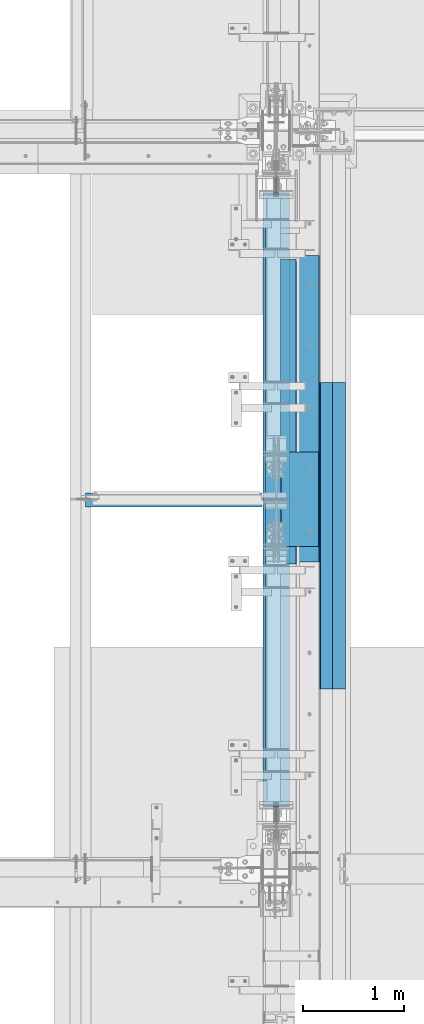
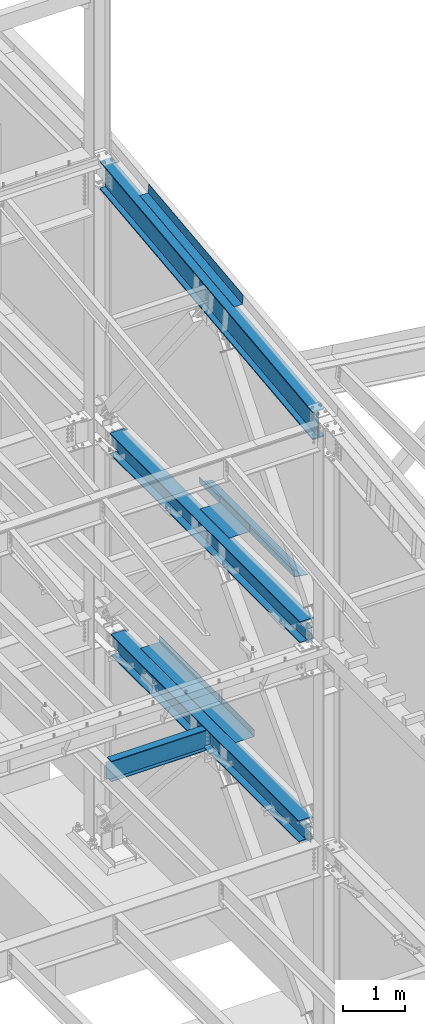
# One storey, part 742 of 1179: 9 beams, 6 elements without a shape of their own.
"""IFC2X3 building model written with IfcOpenShell, lengths in millimetres."""

from ifc_helpers import new_model, si_unit, frame, origin_with_axes, place, context, subcontext, project, spatial, faceted_brep, material, type_object, element, aggregate, save


model = new_model("IFC2X3")

# Units and contexts
model_context = context("Model", 3, precision=1e-05, world=origin_with_axes())
body_context = subcontext(model_context, "Body", "Model", "MODEL_VIEW")
ifc_project = project(units=[si_unit("LENGTHUNIT", "METRE", prefix="MILLI"), si_unit("AREAUNIT", "SQUARE_METRE"), si_unit("VOLUMEUNIT", "CUBIC_METRE"), si_unit("MASSUNIT", "GRAM", prefix="KILO"), si_unit("TIMEUNIT", "SECOND"), si_unit("PLANEANGLEUNIT", "RADIAN"), si_unit("SOLIDANGLEUNIT", "STERADIAN"), si_unit("THERMODYNAMICTEMPERATUREUNIT", "DEGREE_CELSIUS"), si_unit("LUMINOUSINTENSITYUNIT", "LUMEN")], contexts=[model_context])

# Site, building, storey
site_placement = place(None, origin_with_axes())
site = spatial("IfcSite", under=ifc_project, at=site_placement, CompositionType="ELEMENT")
building_placement = place(site_placement, origin_with_axes())
building = spatial("IfcBuilding", under=site, at=building_placement, Name="Undefined", CompositionType="ELEMENT")
storey_placement = place(building_placement, origin_with_axes())
storey = spatial("IfcBuildingStorey", under=building, at=storey_placement, Name="Undefined", CompositionType="ELEMENT", Elevation=0.0)

# Assembly, beam
assembly_1_placement = place(storey_placement, origin_with_axes())
assembly_1 = element("IfcElementAssembly", 1, at=assembly_1_placement, inside=storey, Name="BEAM", AssemblyPlace="NOTDEFINED", PredefinedType="RIGID_FRAME")
ifc_material_1 = material(Name="STEEL/A992")
beam_type_1 = type_object("IfcBeamType", Name="W16X31", PredefinedType="NOTDEFINED")
beam_1_placement = place(assembly_1_placement, frame((22326.6, 30721.3, 3900.4875), z_axis=(0.0, 0.0, 1.0), x_axis=(1.0, 0.0, 0.0)))
beam_1 = element("IfcBeam", 2, at=beam_1_placement, type_object=beam_type_1, material=ifc_material_1, Name="BEAM", ObjectType="W16X31", context=body_context, shape_type="Brep", body=[
    faceted_brep([(15.875, -3.17499999999927, -169.8625), (15.875, 3.17499999999927, -169.8625), (69.8500001907269, 3.17499999999927, -169.8625), (69.8500001907269, -3.17499999999927, -169.8625), (74.7100797087733, 3.17499999999927, -170.829229922588), (74.7100797087733, -3.17499999999927, -170.829229922588), (78.8302561769269, 3.17499999999927, -173.582243823066), (78.8302561769269, -3.17499999999927, -173.582243823066), (81.5832700774044, 3.17499999999927, -177.70242029122), (81.5832700774044, -3.17499999999927, -177.70242029122), (82.549999999992, -3.17499999999927, -182.562499809265), (82.549999999992, 3.17499999999927, -182.562499809265), (82.549999999992, 3.17499999999927, -190.5), (82.549999999992, 69.8499999999985, -190.5), (82.549999999992, 69.8499999999985, -201.6125), (82.549999999992, -69.8499999999985, -201.6125), (82.549999999992, -69.8499999999985, -190.5), (82.549999999992, -3.17499999999927, -190.5), (1839.11875, 69.8499999999985, 190.5), (1839.11875, 3.17499999999927, 190.5), (82.549999999992, 3.17499999999927, 190.5), (82.549999999992, 69.8499999999985, 190.5), (69.8500001907269, -3.17499999999927, 169.8625), (69.8500001907269, 3.17499999999927, 169.8625), (15.875, 3.17499999999927, 169.8625), (15.875, -3.17499999999927, 169.8625), (74.7100797087733, -3.17499999999927, 170.829229922588), (74.7100797087733, 3.17499999999927, 170.829229922588), (78.8302561769269, -3.17499999999927, 173.582243823066), (78.8302561769269, 3.17499999999927, 173.582243823066), (81.5832700774044, -3.17499999999927, 177.70242029122), (81.5832700774044, 3.17499999999927, 177.70242029122), (82.549999999992, -3.17499999999927, 182.562499809265), (82.549999999992, 3.17499999999927, 182.562499809265), (1839.11875, -69.8499999999985, 201.6125), (1839.11875, 69.8499999999985, 201.6125), (82.549999999992, 69.8499999999985, 201.6125), (82.549999999992, -69.8499999999985, 201.6125), (1839.11875, -69.8499999999985, 190.5), (82.549999999992, -69.8499999999985, 190.5), (1839.11875, -3.17499999999927, 190.5), (82.549999999992, -3.17499999999927, 190.5), (1839.11875, -3.17499999999927, 169.862499809265), (1839.11875, 3.17499999999927, 169.862499809265), (1840.08547992259, -3.17499999999927, 165.00242029122), (1840.08547992259, 3.17499999999927, 165.00242029122), (1842.83849382307, -3.17499999999927, 160.882243823066), (1842.83849382307, 3.17499999999927, 160.882243823066), (1846.95867029122, -3.17499999999927, 158.129229922588), (1846.95867029122, 3.17499999999927, 158.129229922588), (1851.81874980927, -3.17499999999927, 157.1625), (1851.81874980927, 3.17499999999927, 157.1625), (1962.94375000001, -3.17499999999927, 157.1625), (1962.94375000001, 3.17499999999927, 157.1625), (1962.94375000001, -3.17499999999927, -157.1625), (1962.94375000001, 3.17499999999927, -157.1625), (1851.81874980927, -3.17499999999927, -157.1625), (1851.81874980927, 3.17499999999927, -157.1625), (1846.95867029122, -3.17499999999927, -158.129229922588), (1846.95867029122, 3.17499999999927, -158.129229922588), (1842.83849382307, -3.17499999999927, -160.882243823066), (1842.83849382307, 3.17499999999927, -160.882243823066), (1840.08547992259, -3.17499999999927, -165.00242029122), (1840.08547992259, 3.17499999999927, -165.00242029122), (1839.11875, -3.17499999999927, -169.862499809266), (1839.11875, 3.17499999999927, -169.862499809266), (1839.11875, -3.17499999999927, -190.5), (1839.11875, -69.8499999999985, -190.5), (1839.11875, -69.8499999999985, -201.6125), (1839.11875, 69.8499999999985, -201.6125), (1839.11875, 69.8499999999985, -190.5), (1839.11875, 3.17499999999927, -190.5)], [[[0, 1, 2, 3]], [[3, 2, 4, 5]], [[5, 4, 6, 7]], [[7, 6, 8, 9]], [[10, 11, 12, 13, 14, 15, 16, 17]], [[9, 8, 11, 10]], [[18, 19, 20, 21]], [[22, 23, 24, 25]], [[26, 27, 23, 22]], [[28, 29, 27, 26]], [[30, 31, 29, 28]], [[32, 33, 31, 30]], [[34, 35, 36, 37]], [[38, 34, 37, 39]], [[40, 38, 39, 41]], [[37, 36, 21, 20, 33, 32, 41, 39]], [[35, 18, 21, 36]], [[34, 38, 40, 42, 43, 19, 18, 35]], [[44, 45, 43, 42]], [[46, 47, 45, 44]], [[48, 49, 47, 46]], [[50, 51, 49, 48]], [[52, 53, 51, 50]], [[53, 52, 54, 55]], [[54, 56, 57, 55]], [[58, 59, 57, 56]], [[60, 61, 59, 58]], [[62, 63, 61, 60]], [[64, 65, 63, 62]], [[66, 67, 68, 69, 70, 71, 65, 64]], [[67, 66, 17, 16]], [[68, 67, 16, 15]], [[69, 68, 15, 14]], [[70, 69, 14, 13]], [[71, 70, 13, 12]], [[6, 4, 2, 1, 24, 23, 27, 29, 31, 33, 20, 19, 43, 45, 47, 49, 51, 53, 55, 57, 59, 61, 63, 65, 71, 12, 11, 8]], [[25, 24, 1, 0]], [[66, 64, 62, 60, 58, 56, 54, 52, 50, 48, 46, 44, 42, 40, 41, 32, 30, 28, 26, 22, 25, 0, 3, 5, 7, 9, 10, 17]]]),
])
aggregate(assembly_1, [beam_1])

assembly_2_placement = place(storey_placement, origin_with_axes())
assembly_2 = element("IfcElementAssembly", 3, at=assembly_2_placement, inside=storey, Name="BEAM", AssemblyPlace="NOTDEFINED", PredefinedType="RIGID_FRAME")
ifc_material_2 = material(Name="STEEL/A36")
beam_type_2 = type_object("IfcBeamType", PredefinedType="NOTDEFINED")
beam_2_placement = place(assembly_2_placement, frame((24350.663, 31596.8008477536, 12820.4719325698), z_axis=(0.0, -0.993676146336441, -0.112284087038017), x_axis=(1.0, 0.0, 0.0)))
beam_2 = element("IfcBeam", 4, at=beam_2_placement, type_object=beam_type_2, material=ifc_material_2, Name="BENT_PLATE", context=body_context, shape_type="Brep", body=[
    faceted_brep([(0.0, -3.17499999999927, -1524.0), (6.00266503170133e-10, -3.17499999922438, 1524.00000000052), (6.00266503170133e-10, 3.17500000077416, 1524.00000000052), (0.0, 3.17499999999927, -1524.0), (153.987000024775, 3.17499999922438, 1524.00000000046), (153.987000022519, 3.17500000077052, -1524.00000000059), (160.337000000047, -3.17500000061591, -1523.99999999915), (160.336999999981, -3.17499999938082, 1523.99999999915), (153.987000000016, 187.325000000103, 1523.99999999907), (153.987000000016, 187.324999998867, -1523.99999999923), (160.337000000014, 187.325000000103, 1523.99999999907), (160.337000000014, 187.324999998867, -1523.99999999923)], [[[0, 1, 2, 3]], [[3, 2, 4, 5]], [[1, 0, 6, 7]], [[5, 4, 8, 9]], [[4, 2, 1, 7, 10, 8]], [[7, 6, 11, 10]], [[6, 0, 3, 5, 9, 11]], [[10, 11, 9, 8]]]),
])

assembly_3_placement = place(storey_placement, origin_with_axes())
assembly_3 = element("IfcElementAssembly", 5, at=assembly_3_placement, inside=storey, Name="PLATE", AssemblyPlace="NOTDEFINED", PredefinedType="RIGID_FRAME")
beam_type_3 = type_object("IfcBeamType", PredefinedType="NOTDEFINED")
beam_3_placement = place(assembly_3_placement, frame((24880.9652345644, 28841.6999999996, 7964.0487255808), z_axis=(-0.99100656978554, 0.0, 0.133813222971043), x_axis=(0.0, 1.0, 0.0)))
beam_3 = element("IfcBeam", 6, at=beam_3_placement, type_object=beam_type_3, material=ifc_material_2, Name="PLATE", context=body_context, shape_type="Brep", body=[
    faceted_brep([(0.0, 4.76249999999709, -114.3), (0.0, 4.76249999999709, 114.3), (3048.0, 4.76249999996799, 114.300000000025), (3048.0, 4.76250000002983, -114.300000000025), (0.0, -4.76249999999709, 114.3), (3048.0, -4.76250000003711, 114.300000000014), (0.0, -4.76249999999709, -114.3), (3048.0, -4.76249999997344, -114.300000000036)], [[[0, 1, 2, 3]], [[1, 4, 5, 2]], [[4, 6, 7, 5]], [[6, 0, 3, 7]], [[5, 7, 3, 2]], [[6, 4, 1, 0]]]),
])
aggregate(assembly_3, [beam_3])

assembly_4_placement = place(storey_placement, origin_with_axes())
assembly_4 = element("IfcElementAssembly", 7, at=assembly_4_placement, inside=storey, Name="BEAM", AssemblyPlace="NOTDEFINED", PredefinedType="RIGID_FRAME")
beam_type_4 = type_object("IfcBeamType", PredefinedType="NOTDEFINED")
beam_4_placement = place(assembly_4_placement, frame((24387.175012207, 31626.175, 4105.275), z_axis=(0.0, -1.0, 0.0), x_axis=(1.0, 0.0, 0.0)))
beam_4 = element("IfcBeam", 8, at=beam_4_placement, type_object=beam_type_4, material=ifc_material_2, Name="BENT_PLATE", context=body_context, shape_type="Brep", body=[
    faceted_brep([(0.0, -3.17499999999927, -1524.0), (6.00266503170133e-10, -3.17499999922438, 1524.00000000052), (6.00266503170133e-10, 3.17500000077416, 1524.00000000052), (0.0, 3.17499999999927, -1524.0), (346.07498779297, 3.17500000000109, 1524.0), (346.07498779297, 3.17500000000109, -1524.0), (352.424987792969, -3.17499999999927, -1524.0), (352.424987792969, -3.17499999999927, 1524.0), (346.07498779297, 130.175006103515, 1524.0), (346.07498779297, 130.175006103515, -1524.0), (352.424987792969, 130.175006103515, 1524.0), (352.424987792969, 130.175006103515, -1524.0)], [[[0, 1, 2, 3]], [[3, 2, 4, 5]], [[1, 0, 6, 7]], [[5, 4, 8, 9]], [[4, 2, 1, 7, 10, 8]], [[7, 6, 11, 10]], [[6, 0, 3, 5, 9, 11]], [[10, 11, 9, 8]]]),
])

assembly_5_placement = place(storey_placement, origin_with_axes())
assembly_5 = element("IfcElementAssembly", 9, at=assembly_5_placement, inside=storey, Name="BEAM", AssemblyPlace="NOTDEFINED", PredefinedType="RIGID_FRAME")
beam_type_5 = type_object("IfcBeamType", PredefinedType="NOTDEFINED")
beam_5_placement = place(assembly_5_placement, frame((24361.7750019084, 30727.6499996401, 8018.4625), z_axis=(0.0, 1.0, 0.0), x_axis=(1.0, 0.0, 0.0)))
beam_5 = element("IfcBeam", 10, at=beam_5_placement, type_object=beam_type_5, material=ifc_material_2, Name="BENT_PLATE", context=body_context, shape_type="Brep", body=[
    faceted_brep([(1.15323928184807e-09, -4.76249999999982, -469.900000000001), (3.16504156216979e-10, -4.76249999999982, 469.900000000001), (-1.14960130304098e-09, 4.76249999999982, 469.900000000001), (-3.12866177409887e-10, 4.76249999999982, -469.900000000001), (377.825003325797, 4.76250005815837, 469.900000000336), (377.825003326634, 4.76250005815837, -469.899999999663), (368.300003174245, -4.76249994330828, -469.89999999967), (368.300003173408, -4.76249994330828, 469.900000000333), (377.825001192323, -128.587512194506, 469.900000000336), (377.82500119316, -128.587512194506, -469.899999999663), (368.300001192321, -128.587512042115, 469.900000000333), (368.300001193158, -128.587512042115, -469.89999999967)], [[[0, 1, 2, 3]], [[3, 2, 4, 5]], [[1, 0, 6, 7]], [[5, 4, 8, 9]], [[4, 2, 1, 7, 10, 8]], [[7, 6, 11, 10]], [[6, 0, 3, 5, 9, 11]], [[10, 11, 9, 8]]]),
])

assembly_6_placement = place(storey_placement, origin_with_axes())
assembly_6 = element("IfcElementAssembly", 11, at=assembly_6_placement, inside=storey, Name="BENT_PLATE", AssemblyPlace="NOTDEFINED", PredefinedType="RIGID_FRAME")
beam_type_6 = type_object("IfcBeamType", PredefinedType="NOTDEFINED")
beam_6_placement = place(assembly_6_placement, frame((24744.362499997, 30365.6999999996, 8102.29217706219), z_axis=(0.0, 1.0, 0.0), x_axis=(0.0, 0.0, -1.0)))
beam_6 = element("IfcBeam", 12, at=beam_6_placement, type_object=beam_type_6, material=ifc_material_2, Name="BENT_PLATE", context=body_context, shape_type="Brep", body=[
    faceted_brep([(-2.91038304567337e-11, -4.76250000000073, -1524.0), (-2.91038304567337e-11, -4.76250000000073, 1524.0), (2.91038304567337e-11, 4.76250000000073, 1524.0), (2.91038304567337e-11, 4.76250000000073, -1524.0), (114.300008765535, 4.76250001759399, 1524.0000000001), (114.300003051474, 4.7625000005828, -1524.0), (105.977955544956, -4.76249999945867, -1524.0), (105.977955544956, -4.76249999945867, 1524.0), (131.343048095475, -121.088742065571, 1524.0), (131.343048095475, -121.088742065571, -1524.0), (121.904205090902, -122.366970423507, 1524.0), (121.904205090902, -122.366970423507, -1524.0)], [[[0, 1, 2, 3]], [[3, 2, 4, 5]], [[1, 0, 6, 7]], [[5, 4, 8, 9]], [[4, 2, 1, 7, 10, 8]], [[7, 6, 11, 10]], [[6, 0, 3, 5, 9, 11]], [[10, 11, 9, 8]]]),
])
aggregate(assembly_6, [beam_6])

# Beam
beam_type_7 = type_object("IfcBeamType", Name="W21X93", PredefinedType="NOTDEFINED")
beam_7_placement = place(assembly_2_placement, frame((24307.8, 27081.8467562485, 12030.7075801958), z_axis=(0.0, -0.112284087038017, 0.993676146336441), x_axis=(0.0, 0.993676146336441, 0.112284087038017)))
beam_7 = element("IfcBeam", 13, at=beam_7_placement, type_object=beam_type_7, material=ifc_material_1, Name="BEAM", ObjectType="W21X93", context=body_context, shape_type="Brep", body=[
    faceted_brep([(199.930151815766, -106.362499999999, -274.637499999924), (199.930151815766, 106.362499999999, -274.637499999924), (7061.63506944101, 106.362499999999, -274.637500002709), (7061.63506944101, -106.362499999999, -274.637500002709), (202.620932743182, -106.362499999999, -250.824999999939), (202.620932743182, -7.14374999999927, -250.824999999939), (259.306717614098, -7.14374999999927, 250.824999999757), (259.306717614098, -106.362499999999, 250.824999999757), (261.997498541514, -106.362499999999, 274.637499999742), (261.997498541514, 106.362499999999, 274.637499999742), (259.306717614098, 106.362499999999, 250.824999999757), (259.306717614098, 7.14374999999927, 250.824999999757), (259.165541301165, 7.14374999999927, 249.575637438333), (214.511782852362, 7.14374999999927, -145.595003258246), (202.620932743182, 7.14374999999927, -250.824999999939), (202.620932743182, 106.362499999999, -250.824999999939), (7064.32585036842, -106.362499999999, -250.825000002722), (7064.32585036842, -7.14374999999927, -250.825000002722), (7121.01163523934, -7.14374999999927, 250.824999996972), (7121.01163523934, -106.362499999999, 250.824999996972), (7123.70241616675, -106.362499999999, 274.637499996959), (7123.70241616675, 106.362499999999, 274.637499996959), (7121.01163523934, 106.362499999999, 250.824999996972), (7121.01163523934, 7.14374999999927, 250.824999996972), (7114.9805671698, 7.14374999999927, 197.452089946073), (7070.32680872106, 7.14374999999927, -197.718550750044), (7064.32585036842, 7.14374999999927, -250.825000002722), (7064.32585036842, 106.362499999999, -250.825000002722)], [[[0, 1, 2, 3]], [[0, 4, 5, 6, 7, 8, 9, 10, 11, 12, 13, 14, 15, 1]], [[5, 4, 16, 17]], [[6, 5, 17, 18]], [[7, 6, 18, 19]], [[8, 7, 19, 20]], [[9, 8, 20, 21]], [[10, 9, 21, 22]], [[11, 10, 22, 23]], [[14, 13, 12, 11, 23, 24, 25, 26]], [[15, 14, 26, 27]], [[1, 15, 27, 2]], [[26, 25, 24, 23, 22, 21, 20, 19, 18, 17, 16, 3, 2, 27]], [[4, 0, 3, 16]]]),
])

aggregate(assembly_2, [beam_2, beam_7])

beam_type_8 = type_object("IfcBeamType", Name="W16X77", PredefinedType="NOTDEFINED")
beam_8_placement = place(assembly_5_placement, frame((24307.8, 27504.4088209118, 7804.15), z_axis=(0.0, 0.0, 1.0), x_axis=(0.0, 1.0, 0.0)))
beam_8 = element("IfcBeam", 14, at=beam_8_placement, type_object=beam_type_8, material=ifc_material_1, Name="BEAM", ObjectType="W16X77", context=body_context, shape_type="Brep", body=[
    faceted_brep([(172.923581529496, -130.174999999999, 209.55), (172.923581529496, 130.174999999999, 209.55), (161.925002356769, 130.174999999999, 190.5), (161.925002356769, 5.55625000000146, 190.5), (161.695793121518, 5.55625000000146, 190.103), (161.695793121518, -5.55625000000146, 190.103), (161.925002356769, -5.55625000000146, 190.5), (161.925002356769, -130.174999999999, 190.5), (204.788, -5.55625000000146, 190.103), (204.788, 5.55625000000146, 190.103), (219.364364197005, 5.55625000000146, 183.243356973128), (219.364364197005, -5.55625000000146, 183.243356973128), (223.220112806051, 5.55625000000146, 179.929052423035), (223.220112806051, -5.55625000000146, 179.929052423035), (224.821539280802, 5.55625000000146, 175.103407882364), (224.821539280802, -5.55625000000146, 175.103407882364), (223.71233220007, 5.55625000000146, 170.141445403769), (223.71233220007, -5.55625000000146, 170.141445403769), (220.208549695388, 5.55625000000146, 166.457029554976), (220.208549695388, -5.55625000000146, 166.457029554976), (215.308561657253, 5.55625000000146, 165.1), (215.308561657253, -5.55625000000146, 165.1), (12.7000000000007, 5.55625000000146, 165.1), (12.7000000000007, -5.55625000000146, 165.1), (12.7000000000007, 5.55625000000146, -165.1), (12.7000000000007, -5.55625000000146, -165.1), (215.652561657254, 5.55625000000146, -165.1), (215.652561657254, -5.55625000000146, -165.1), (220.552549695389, 5.55625000000146, -166.457029554975), (220.552549695389, -5.55625000000146, -166.457029554975), (224.056332200067, 5.55625000000146, -170.141445403768), (224.056332200067, -5.55625000000146, -170.141445403768), (225.165539280799, 5.55625000000146, -175.103407882363), (225.165539280799, -5.55625000000146, -175.103407882363), (223.564112806052, 5.55625000000146, -179.929052423034), (223.564112806052, -5.55625000000146, -179.929052423034), (219.708364197006, 5.55625000000146, -183.243356973128), (219.708364197006, -5.55625000000146, -183.243356973128), (205.132000000001, 5.55625000000146, -190.103), (205.132000000001, -5.55625000000146, -190.103), (173.152798769261, 5.55625000000146, -190.103), (173.152798769261, -5.55625000000146, -190.103), (6260.85876063778, 5.55625000000146, -190.5), (6260.85876063778, 130.174999999999, -190.5), (172.923597538524, 130.174999999999, -190.5), (172.923597538524, 5.55625000000146, -190.5), (6271.85695571483, 130.174999999999, -209.55), (161.925402461478, 130.174999999999, -209.55), (6271.85695571483, -130.174999999999, -209.55), (161.925402461478, -130.174999999999, -209.55), (6260.85876063778, -130.174999999999, -190.5), (172.923597538524, -130.174999999999, -190.5), (172.923597538524, -5.55625000000146, -190.5), (6260.85876063778, -5.55625000000146, -190.5), (6260.62955940704, 5.55625000000146, -190.103), (6260.62955940704, -5.55625000000146, -190.103), (6228.6503581763, 5.55625000000146, -190.103), (6228.6503581763, -5.55625000000146, -190.103), (6214.0739939793, 5.55625000000146, -183.243356973128), (6214.0739939793, -5.55625000000146, -183.243356973128), (6210.21824537025, 5.55625000000146, -179.929052423035), (6210.21824537025, -5.55625000000146, -179.929052423035), (6208.61681889551, 5.55625000000146, -175.103407882363), (6208.61681889551, -5.55625000000146, -175.103407882363), (6209.72602597623, 5.55625000000146, -170.141445403768), (6209.72602597623, -5.55625000000146, -170.141445403768), (6213.22980848092, 5.55625000000146, -166.457029554975), (6213.22980848092, -5.55625000000146, -166.457029554975), (6218.12979651905, 5.55625000000146, -165.1), (6218.12979651905, -5.55625000000146, -165.1), (6421.0823581763, 5.55625000000146, -165.1), (6421.0823581763, -5.55625000000146, -165.1), (6421.0823581763, -5.55625000000146, 165.1), (6421.0823581763, 5.55625000000146, 165.1), (6218.47379651905, 5.55625000000146, 165.1), (6218.47379651905, -5.55625000000146, 165.1), (6213.57380848091, 5.55625000000146, 166.457029554975), (6213.57380848091, -5.55625000000146, 166.457029554975), (6210.07002597624, 5.55625000000146, 170.141445403767), (6210.07002597624, -5.55625000000146, 170.141445403767), (6208.9608188955, 5.55625000000146, 175.103407882362), (6208.9608188955, -5.55625000000146, 175.103407882362), (6210.56224537025, 5.55625000000146, 179.929052423034), (6210.56224537025, -5.55625000000146, 179.929052423034), (6214.4179939793, 5.55625000000146, 183.243356973128), (6214.4179939793, -5.55625000000146, 183.243356973128), (6228.9943581763, 5.55625000000146, 190.103), (6228.9943581763, -5.55625000000146, 190.103), (6272.08656505479, 5.55625000000146, 190.103), (6272.08656505479, -5.55625000000146, 190.103), (6271.85735581953, -130.174999999999, 190.5), (6271.85735581953, -5.55625000000146, 190.5), (6271.85735581953, 5.55625000000146, 190.5), (6271.85735581953, 130.174999999999, 190.5), (6260.85877664681, 130.174999999999, 209.55), (6260.85877664681, -130.174999999999, 209.55)], [[[0, 1, 2, 3, 4, 5, 6, 7]], [[8, 9, 10, 11]], [[11, 10, 12, 13]], [[13, 12, 14, 15]], [[15, 14, 16, 17]], [[17, 16, 18, 19]], [[19, 18, 20, 21]], [[21, 20, 22, 23]], [[23, 22, 24, 25]], [[26, 27, 25, 24]], [[27, 26, 28, 29]], [[29, 28, 30, 31]], [[31, 30, 32, 33]], [[33, 32, 34, 35]], [[35, 34, 36, 37]], [[37, 36, 38, 39]], [[39, 38, 40, 41]], [[42, 43, 44, 45]], [[43, 46, 47, 44]], [[46, 48, 49, 47]], [[48, 50, 51, 49]], [[41, 40, 45, 44, 47, 49, 51, 52]], [[50, 53, 52, 51]], [[48, 46, 43, 42, 54, 55, 53, 50]], [[56, 57, 55, 54]], [[57, 56, 58, 59]], [[59, 58, 60, 61]], [[61, 60, 62, 63]], [[63, 62, 64, 65]], [[65, 64, 66, 67]], [[67, 66, 68, 69]], [[69, 68, 70, 71]], [[72, 71, 70, 73]], [[74, 75, 72, 73]], [[75, 74, 76, 77]], [[77, 76, 78, 79]], [[79, 78, 80, 81]], [[81, 80, 82, 83]], [[83, 82, 84, 85]], [[85, 84, 86, 87]], [[87, 86, 88, 89]], [[90, 91, 89, 88, 92, 93, 94, 95]], [[90, 95, 0, 7]], [[91, 90, 7, 6]], [[8, 11, 13, 15, 17, 19, 21, 23, 25, 27, 29, 31, 33, 35, 37, 39, 41, 52, 53, 55, 57, 59, 61, 63, 65, 67, 69, 71, 72, 75, 77, 79, 81, 83, 85, 87, 89, 91, 6, 5]], [[9, 8, 5, 4]], [[92, 88, 86, 84, 82, 80, 78, 76, 74, 73, 70, 68, 66, 64, 62, 60, 58, 56, 54, 42, 45, 40, 38, 36, 34, 32, 30, 28, 26, 24, 22, 20, 18, 16, 14, 12, 10, 9, 4, 3]], [[93, 92, 3, 2]], [[94, 93, 2, 1]], [[95, 94, 1, 0]]]),
])

aggregate(assembly_5, [beam_5, beam_8])

beam_9_placement = place(assembly_4_placement, frame((24307.8, 27051.0, 3892.55), z_axis=(0.0, 0.0, 1.0), x_axis=(0.0, 1.0, 0.0)))
beam_9 = element("IfcBeam", 15, at=beam_9_placement, type_object=beam_type_8, material=ifc_material_1, Name="BEAM", ObjectType="W16X77", context=body_context, shape_type="Brep", body=[
    faceted_brep([(660.506582660477, -130.174999999999, 209.55), (660.506582660477, 130.174999999999, 209.55), (649.50800348775, 130.174999999999, 190.5), (649.50800348775, 5.55625000000146, 190.5), (649.278794252499, 5.55625000000146, 190.103), (649.278794252499, -5.55625000000146, 190.103), (649.50800348775, -5.55625000000146, 190.5), (649.50800348775, -130.174999999999, 190.5), (692.371001130981, -5.55625000000146, 190.103), (692.371001130981, 5.55625000000146, 190.103), (706.947365327986, 5.55625000000146, 183.243356973127), (706.947365327986, -5.55625000000146, 183.243356973127), (710.803113937032, 5.55625000000146, 179.929052423032), (710.803113937032, -5.55625000000146, 179.929052423032), (712.404540411782, 5.55625000000146, 175.103407882361), (712.404540411782, -5.55625000000146, 175.103407882361), (711.295333331051, 5.55625000000146, 170.141445403766), (711.295333331051, -5.55625000000146, 170.141445403766), (707.791550826369, 5.55625000000146, 166.457029554974), (707.791550826369, -5.55625000000146, 166.457029554974), (702.891562788234, 5.55625000000146, 165.099999999999), (702.891562788234, -5.55625000000146, 165.099999999999), (500.283001130982, 5.55625000000146, 165.1), (500.283001130982, -5.55625000000146, 165.1), (500.283001130982, 5.55625000000146, -165.1), (500.283001130982, -5.55625000000146, -165.1), (703.235562788235, 5.55625000000146, -165.1), (703.235562788235, -5.55625000000146, -165.1), (708.13555082637, 5.55625000000146, -166.457029554975), (708.13555082637, -5.55625000000146, -166.457029554975), (711.639333331052, 5.55625000000146, -170.141445403767), (711.639333331052, -5.55625000000146, -170.141445403767), (712.748540411783, 5.55625000000146, -175.103407882362), (712.748540411783, -5.55625000000146, -175.103407882362), (711.147113937033, 5.55625000000146, -179.929052423033), (711.147113937033, -5.55625000000146, -179.929052423033), (707.291365327987, 5.55625000000146, -183.243356973127), (707.291365327987, -5.55625000000146, -183.243356973127), (692.715001130982, 5.55625000000146, -190.103), (692.715001130982, -5.55625000000146, -190.103), (660.735799900242, 5.55625000000146, -190.103), (660.735799900242, -5.55625000000146, -190.103), (6680.09340139533, 5.55625000000146, -190.5), (6680.09340139533, 130.174999999999, -190.5), (660.506598669504, 130.174999999999, -190.5), (660.506598669504, 5.55625000000146, -190.5), (6691.09159647237, 130.174999999999, -209.55), (649.508403592459, 130.174999999999, -209.55), (6691.09159647237, -130.174999999999, -209.55), (649.508403592459, -130.174999999999, -209.55), (6680.09340139533, -130.174999999999, -190.5), (660.506598669504, -130.174999999999, -190.5), (660.506598669504, -5.55625000000146, -190.5), (6680.09340139533, -5.55625000000146, -190.5), (6679.86420016459, 5.55625000000146, -190.103), (6679.86420016459, -5.55625000000146, -190.103), (6647.88499893385, 5.55625000000146, -190.103), (6647.88499893385, -5.55625000000146, -190.103), (6633.30863473684, 5.55625000000146, -183.243356973128), (6633.30863473684, -5.55625000000146, -183.243356973128), (6629.45288612779, 5.55625000000146, -179.929052423034), (6629.45288612779, -5.55625000000146, -179.929052423034), (6627.85145965304, 5.55625000000146, -175.103407882363), (6627.85145965304, -5.55625000000146, -175.103407882363), (6628.96066673378, 5.55625000000146, -170.141445403767), (6628.96066673378, -5.55625000000146, -170.141445403767), (6632.46444923846, 5.55625000000146, -166.457029554975), (6632.46444923846, -5.55625000000146, -166.457029554975), (6637.36443727659, 5.55625000000146, -165.1), (6637.36443727659, -5.55625000000146, -165.1), (6840.31699893385, 5.55625000000146, -165.1), (6840.31699893385, -5.55625000000146, -165.1), (6840.31699893385, -5.55625000000146, 165.1), (6840.31699893385, 5.55625000000146, 165.1), (6637.7084372766, 5.55625000000146, 165.1), (6637.7084372766, -5.55625000000146, 165.1), (6632.80844923846, 5.55625000000146, 166.457029554975), (6632.80844923846, -5.55625000000146, 166.457029554975), (6629.30466673378, 5.55625000000146, 170.141445403767), (6629.30466673378, -5.55625000000146, 170.141445403767), (6628.19545965305, 5.55625000000146, 175.103407882362), (6628.19545965305, -5.55625000000146, 175.103407882362), (6629.7968861278, 5.55625000000146, 179.929052423034), (6629.7968861278, -5.55625000000146, 179.929052423034), (6633.65263473684, 5.55625000000146, 183.243356973127), (6633.65263473684, -5.55625000000146, 183.243356973127), (6648.22899893385, 5.55625000000146, 190.103), (6648.22899893385, -5.55625000000146, 190.103), (6691.32120581233, 5.55625000000146, 190.103), (6691.32120581233, -5.55625000000146, 190.103), (6691.09199657707, -130.174999999999, 190.5), (6691.09199657707, -5.55625000000146, 190.5), (6691.09199657707, 5.55625000000146, 190.5), (6691.09199657707, 130.174999999999, 190.5), (6680.09341740435, 130.174999999999, 209.55), (6680.09341740435, -130.174999999999, 209.55)], [[[0, 1, 2, 3, 4, 5, 6, 7]], [[8, 9, 10, 11]], [[11, 10, 12, 13]], [[13, 12, 14, 15]], [[15, 14, 16, 17]], [[17, 16, 18, 19]], [[19, 18, 20, 21]], [[21, 20, 22, 23]], [[23, 22, 24, 25]], [[26, 27, 25, 24]], [[27, 26, 28, 29]], [[29, 28, 30, 31]], [[31, 30, 32, 33]], [[33, 32, 34, 35]], [[35, 34, 36, 37]], [[37, 36, 38, 39]], [[39, 38, 40, 41]], [[42, 43, 44, 45]], [[43, 46, 47, 44]], [[46, 48, 49, 47]], [[48, 50, 51, 49]], [[41, 40, 45, 44, 47, 49, 51, 52]], [[50, 53, 52, 51]], [[48, 46, 43, 42, 54, 55, 53, 50]], [[56, 57, 55, 54]], [[57, 56, 58, 59]], [[59, 58, 60, 61]], [[61, 60, 62, 63]], [[63, 62, 64, 65]], [[65, 64, 66, 67]], [[67, 66, 68, 69]], [[69, 68, 70, 71]], [[72, 71, 70, 73]], [[74, 75, 72, 73]], [[75, 74, 76, 77]], [[77, 76, 78, 79]], [[79, 78, 80, 81]], [[81, 80, 82, 83]], [[83, 82, 84, 85]], [[85, 84, 86, 87]], [[87, 86, 88, 89]], [[90, 91, 89, 88, 92, 93, 94, 95]], [[90, 95, 0, 7]], [[91, 90, 7, 6]], [[8, 11, 13, 15, 17, 19, 21, 23, 25, 27, 29, 31, 33, 35, 37, 39, 41, 52, 53, 55, 57, 59, 61, 63, 65, 67, 69, 71, 72, 75, 77, 79, 81, 83, 85, 87, 89, 91, 6, 5]], [[9, 8, 5, 4]], [[92, 88, 86, 84, 82, 80, 78, 76, 74, 73, 70, 68, 66, 64, 62, 60, 58, 56, 54, 42, 45, 40, 38, 36, 34, 32, 30, 28, 26, 24, 22, 20, 18, 16, 14, 12, 10, 9, 4, 3]], [[93, 92, 3, 2]], [[94, 93, 2, 1]], [[95, 94, 1, 0]]]),
])

aggregate(assembly_4, [beam_4, beam_9])

save(model, "model.ifc")
